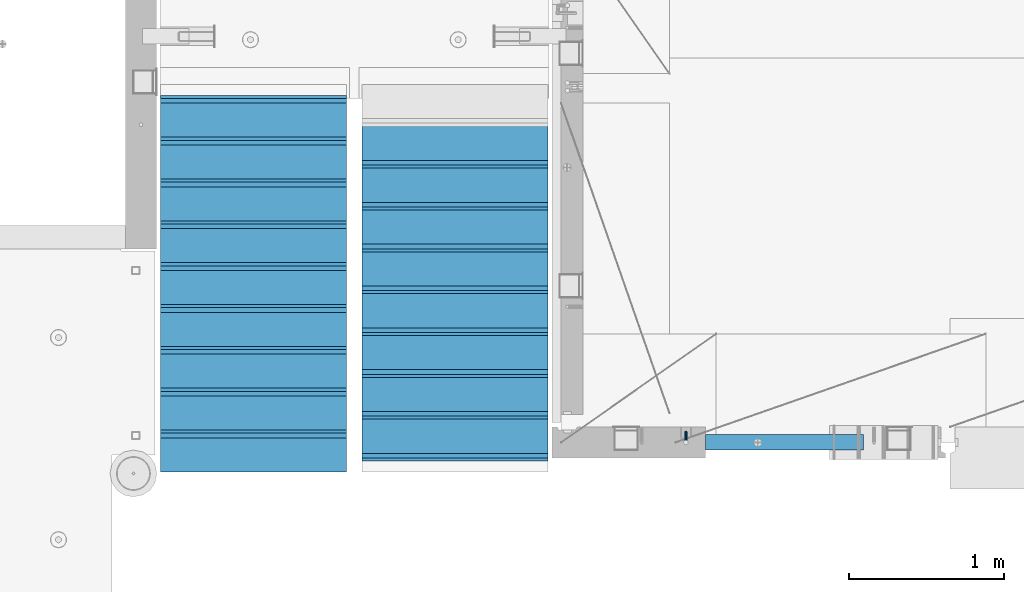
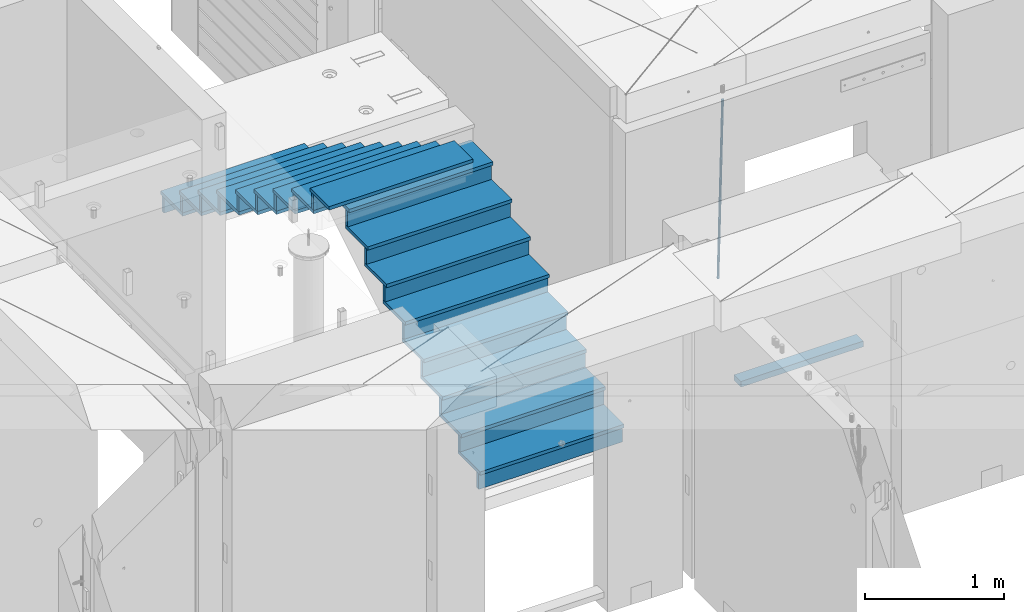
# One storey, part 113 of 334: 36 beams, 3 elements without a shape of their own.
"""IFC2X3 building model written with IfcOpenShell, lengths in millimetres."""

import ifcopenshell
import ifcopenshell.guid

model = None  # the IFC model being written
_history = None  # IfcOwnerHistory: only IFC2X3 demands one
_inside = {}  # id of a spatial element -> (the spatial element, [elements in it])
_under = {}  # id of a project, library or spatial element -> (it, [spatial elements below it])
_declared = {}  # id of a project -> (the project, [libraries it declares])
_typed = {}  # id of a type object -> (the type object, [elements of that type])
_made_of = {}  # id of a material, layer set ... -> (it, [elements and type objects made of it])


def new_model(schema):
    """Start an empty IFC model of exactly this schema.

    Asked for "IFC4X3", IfcOpenShell would pick the latest addendum, in which some entities
    have other attributes; the version numbers below select the first issue.
    IFC2X3 requires an IfcOwnerHistory on every rooted entity: one is made here for all.
    """
    global model, _history
    if schema == "IFC4X3":
        model = ifcopenshell.file(schema_version=(4, 3, 0, 0))
    else:
        model = ifcopenshell.file(schema=schema)
    _inside.clear()
    _under.clear()
    _declared.clear()
    _typed.clear()
    _made_of.clear()
    _history = None
    if model.schema == "IFC2X3":
        org = make("IfcOrganization", Name="unknown")
        user = make(
            "IfcPersonAndOrganization",
            ThePerson=make("IfcPerson", FamilyName="unknown"),
            TheOrganization=org,
        )
        app = make(
            "IfcApplication",
            ApplicationDeveloper=org,
            Version="unknown",
            ApplicationFullName="unknown",
            ApplicationIdentifier="unknown",
        )
        _history = make(
            "IfcOwnerHistory",
            OwningUser=user,
            OwningApplication=app,
            ChangeAction="ADDED",
            CreationDate=0,
        )
    return model


def make(cls, **values):
    """One entity of the class cls with the attributes given. An attribute that is None is left unset."""
    return model.create_entity(
        cls, **{name: value for name, value in values.items() if value is not None}
    )


def rooted(cls, **values):
    """An entity with a GlobalId (a new one), such as an element, a storey or a relation."""
    return make(cls, GlobalId=ifcopenshell.guid.new(), OwnerHistory=_history, **values)


def si_unit(unit_type, name, prefix=None):
    """IfcSIUnit, for example si_unit("LENGTHUNIT", "METRE", prefix="MILLI")."""
    return make("IfcSIUnit", UnitType=unit_type, Prefix=prefix, Name=name)


def assignment(units):
    """IfcUnitAssignment: the units of a project."""
    return None if units is None else make("IfcUnitAssignment", Units=units)


def point(xyz):
    """IfcCartesianPoint."""
    return None if xyz is None else make("IfcCartesianPoint", Coordinates=xyz)


def direction(xyz):
    """IfcDirection."""
    return None if xyz is None else make("IfcDirection", DirectionRatios=xyz)


def frame(location, z_axis=None, x_axis=None):
    """IfcAxis2Placement3D, a coordinate frame: its origin and axes. An axis left out is left unset."""
    return make(
        "IfcAxis2Placement3D",
        Location=point(location),
        Axis=direction(z_axis),
        RefDirection=direction(x_axis),
    )


def origin_with_axes():
    """The frame at (0, 0, 0) with the z axis (0, 0, 1) and the x axis (1, 0, 0) written out."""
    return frame((0.0, 0.0, 0.0), z_axis=(0.0, 0.0, 1.0), x_axis=(1.0, 0.0, 0.0))


def place(relative_to, where):
    """IfcLocalPlacement: puts the frame where relative to a parent placement (None: the world)."""
    return make(
        "IfcLocalPlacement", PlacementRelTo=relative_to, RelativePlacement=where
    )


def context(
    kind, dimensions, precision=None, world=None, true_north=None, identifier=None
):
    """IfcGeometricRepresentationContext, for example the 3D "Model" context."""
    return make(
        "IfcGeometricRepresentationContext",
        ContextIdentifier=identifier,
        ContextType=kind,
        CoordinateSpaceDimension=dimensions,
        Precision=precision,
        WorldCoordinateSystem=world,
        TrueNorth=true_north,
    )


def subcontext(parent, identifier, kind, view, scale=None):
    """IfcGeometricRepresentationSubContext, for example "Body" below "Model"."""
    return make(
        "IfcGeometricRepresentationSubContext",
        ContextIdentifier=identifier,
        ContextType=kind,
        ParentContext=parent,
        TargetScale=scale,
        TargetView=view,
    )


def project(units=None, contexts=None):
    """IfcProject with its units and contexts."""
    return rooted(
        "IfcProject",
        Name="project",
        RepresentationContexts=contexts,
        UnitsInContext=assignment(units),
    )


def spatial(cls, under=None, at=None, **own):
    """A site, building, storey or space (cls), placed at a placement, below another one or the project."""
    s = rooted(cls, ObjectPlacement=at, **own)
    if under is not None:
        _under.setdefault(under.id(), (under, []))[1].append(s)
    return s


def faces_of(points, faces, orient=None, outer=None):
    """IfcFace entities. A face is a list of loops; a loop is a list of indices into points, from 0.

    orient and outer hold one flag for each loop. By default every Orientation is true, the
    first loop of a face is its IfcFaceOuterBound and the others are IfcFaceBound.
    """
    made = []
    for i, loops in enumerate(faces):
        bounds = []
        for j, loop in enumerate(loops):
            is_outer = j == 0 if outer is None else outer[i][j]
            bounds.append(
                make(
                    "IfcFaceOuterBound" if is_outer else "IfcFaceBound",
                    Bound=make("IfcPolyLoop", Polygon=[points[k] for k in loop]),
                    Orientation=True if orient is None else orient[i][j],
                )
            )
        made.append(make("IfcFace", Bounds=bounds))
    return made


def faceted_brep(points, faces, orient=None, outer=None, voids=None):
    """IfcFacetedBrep: a solid bounded by flat faces; with voids (closed shells), ...WithVoids."""
    shared = [point(p) for p in points]
    hull = make("IfcClosedShell", CfsFaces=faces_of(shared, faces, orient, outer))
    if voids is None:
        return make("IfcFacetedBrep", Outer=hull)
    return make(
        "IfcFacetedBrepWithVoids",
        Outer=hull,
        Voids=[
            make(cls, CfsFaces=faces_of(shared, fs, o, b)) for cls, fs, o, b in voids
        ],
    )


def shape(context_of_items, identifier, shape_type, items):
    """IfcShapeRepresentation: the items that make up one representation, for example the "Body"."""
    return make(
        "IfcShapeRepresentation",
        ContextOfItems=context_of_items,
        RepresentationIdentifier=identifier,
        RepresentationType=shape_type,
        Items=items,
    )


def material(Name=None, Category=None):
    """IfcMaterial."""
    return make("IfcMaterial", Name=Name, Category=Category)


def made_of(thing, what):
    """Note that an element or type object is made of a material, layer set ...; save() writes the relation."""
    if what is not None:
        _made_of.setdefault(what.id(), (what, []))[1].append(thing)
    return thing


def type_object(cls, material=None, **own):
    """A type object (cls), such as IfcWallType, which elements share."""
    return made_of(rooted(cls, **own), material)


def element(
    cls,
    number,
    at=None,
    inside=None,
    cuts=None,
    type_object=None,
    material=None,
    context=None,
    identifier="Body",
    shape_type=None,
    held_by="IfcProductDefinitionShape",
    body=None,
    shapes=None,
    **own,
):
    """One element of the class cls, such as IfcWall. Its Tag is "e" and its number.

    at: its placement. inside: the storey or other place that contains it. cuts: it is an
    opening in that element (IfcRelVoidsElement). A single representation is given by context,
    identifier, shape_type and body (its items); several are given by shapes. held_by: the class
    of the entity that holds the representations. save() writes the other relations.
    """
    e = rooted(cls, Tag="e%d" % number, ObjectPlacement=at, **own)
    if body is not None:
        shapes = [shape(context, identifier, shape_type, body)]
    if shapes is not None:
        e.Representation = make(held_by, Representations=shapes)
    if inside is not None:
        _inside.setdefault(inside.id(), (inside, []))[1].append(e)
    if cuts is not None:
        rooted(
            "IfcRelVoidsElement", RelatingBuildingElement=cuts, RelatedOpeningElement=e
        )
    if type_object is not None:
        _typed.setdefault(type_object.id(), (type_object, []))[1].append(e)
    return made_of(e, material)


def aggregate(whole, parts):
    """IfcRelAggregates: a whole, such as a stair, and the parts it consists of."""
    return rooted("IfcRelAggregates", RelatingObject=whole, RelatedObjects=parts)


def save(model, path):
    """Write the relations noted so far, then the file.

    IfcRelAggregates (storeys below a building ...), IfcRelContainedInSpatialStructure (elements
    in a storey), IfcRelDefinesByType, IfcRelAssociatesMaterial and IfcRelDeclares: one each for
    every whole, place, type object, material and project.
    """
    for whole, parts in _under.values():
        aggregate(whole, parts)
    for where, things in _inside.values():
        rooted(
            "IfcRelContainedInSpatialStructure",
            RelatedElements=things,
            RelatingStructure=where,
        )
    for kind, things in _typed.values():
        rooted("IfcRelDefinesByType", RelatedObjects=things, RelatingType=kind)
    for what, things in _made_of.values():
        rooted("IfcRelAssociatesMaterial", RelatedObjects=things, RelatingMaterial=what)
    for by, libraries in _declared.values():
        rooted("IfcRelDeclares", RelatingContext=by, RelatedDefinitions=libraries)
    model.write(path)


model = new_model("IFC2X3")

# Units and contexts
model_context = context("Model", 3, precision=1e-05, world=origin_with_axes())
body_context = subcontext(model_context, "Body", "Model", "MODEL_VIEW")
ifc_project = project(units=[si_unit("LENGTHUNIT", "METRE", prefix="MILLI"), si_unit("AREAUNIT", "SQUARE_METRE"), si_unit("VOLUMEUNIT", "CUBIC_METRE"), si_unit("MASSUNIT", "GRAM", prefix="KILO"), si_unit("TIMEUNIT", "SECOND"), si_unit("PLANEANGLEUNIT", "RADIAN"), si_unit("SOLIDANGLEUNIT", "STERADIAN"), si_unit("THERMODYNAMICTEMPERATUREUNIT", "DEGREE_CELSIUS"), si_unit("LUMINOUSINTENSITYUNIT", "LUMEN")], contexts=[model_context])

# Site, building, storey
site_placement = place(None, origin_with_axes())
site = spatial("IfcSite", under=ifc_project, at=site_placement, CompositionType="ELEMENT")
building_placement = place(site_placement, origin_with_axes())
building = spatial("IfcBuilding", under=site, at=building_placement, CompositionType="ELEMENT")
storey_placement = place(building_placement, origin_with_axes())
storey = spatial("IfcBuildingStorey", under=building, at=storey_placement, Name="3", CompositionType="ELEMENT", Elevation=0.0)

# Assembly, beams
assembly_1_placement = place(storey_placement, origin_with_axes())
assembly_1 = element("IfcElementAssembly", 1, at=assembly_1_placement, inside=storey, AssemblyPlace="NOTDEFINED", PredefinedType="REINFORCEMENT_UNIT")
ifc_material_1 = material()
beam_type_1 = type_object("IfcBeamType", Name="D20", PredefinedType="NOTDEFINED")
beam_1_placement = place(assembly_1_placement, frame((23075.0006866416, 17045.0000022791, 88790.0), z_axis=(0.00020576299992186, -0.999642804629538, -0.0267249099901004), x_axis=(-4.30000201928125e-08, -0.0267249099948059, 0.999642825806181)))
beam_1 = element("IfcBeam", 2, at=beam_1_placement, type_object=beam_type_1, material=ifc_material_1, Name="JM20", ObjectType="D20", context=body_context, shape_type="Brep", body=[
    faceted_brep([(0.0, -10.0, 0.0), (-4.19531716033816e-08, -7.07106781186667, -7.07106781187031), (60.4266690400545, -7.0710677960451, -7.07106780570757), (60.4266690441291, -9.99999998418934, 6.15546014159918e-09), (0.0, 0.0, -10.0), (60.426669036824, 1.58106558956206e-08, -9.99999999384454), (4.196772351861e-08, 7.07106781186303, -7.07106781186667), (60.4266690363438, 7.07106782768096, -7.07106780570757), (0.0, 10.0, 0.0), (60.4266690388904, 10.0000000158179, 6.15182216279209e-09), (4.196772351861e-08, 7.07106781185939, 7.07106781185939), (60.4266690429649, 7.07106782768096, 7.07106781802577), (0.0, 0.0, 10.0), (60.4266690461809, 1.58179318532348e-08, 10.0000000061555), (-4.19531716033816e-08, -7.07106781187031, 7.07106781185939), (60.4266690466611, -7.07106779605238, 7.07106781802213), (61.0378400410118, -7.07106779588503, -7.07106780564936), (60.991799419251, -9.99999998403655, 6.21366780251265e-09), (61.0569027789461, 1.5985278878361e-08, -9.99999999378269), (61.0378209396877, 7.07106782784831, -7.07106780564936), (60.9917724058905, 10.0000000159635, 6.21366780251265e-09), (60.9457317841297, 7.07106782781193, 7.0710678180767), (60.9266690461809, 1.59488990902901e-08, 10.0000000062028), (60.9457508854539, -7.07106779591413, 7.0710678180767), (61.6489592143771, -7.07106614513759, -7.06310863441468), (61.5568818710308, -9.9999984576425, 0.00735959856683621), (61.6870830769039, 1.71821739058942e-06, -9.99179257185824), (61.6489210170112, 7.07106947854481, -7.06310888312146), (61.556827851804, 10.0000015422847, 0.00735924683976918), (61.4647505084577, 7.07106922979438, 7.07782747982128), (61.4266266459163, 1.36643211590126e-06, 10.0065114172685), (61.464788705809, -7.07106639389531, 7.07782772852806), (176.543135720174, -7.07075579406956, -5.56673531796696), (176.451058376813, -9.99968810657447, 1.50373291501455), (176.581259582701, 0.000312069292704109, -8.49541925541052), (176.543097522794, 7.07137982961285, -5.56673556667374), (176.451004357587, 10.00031189336, 1.50373256329476), (176.35892701424, 7.07137958085514, 8.57420079627263), (176.320803151699, 0.000311717507429421, 11.5028847337162), (176.358965211621, -7.07075604281999, 8.57420104497578), (177.098753836006, -7.07075429323595, -5.55949898843028), (176.98362511232, -9.99968666800123, 1.510669025065), (177.146421932586, 0.000313595905026887, -8.48805862247536), (177.098706077581, 7.07138133041735, -5.55949936166144), (176.983557571715, 10.0003133318824, 1.51066849724157), (176.868428848029, 7.07138095712435, 8.58083651073321), (176.820760751449, 0.000313067976094317, 11.5093961447819), (176.868476606425, -7.07075466652896, 8.58083688396073), (177.654312950661, -7.07075204110879, -5.54863964998367), (177.516135294456, -9.99968450931192, 1.52107783331303), (177.711524267797, 0.000315886711177882, -8.47701274570863), (177.654255632195, 7.07138358250813, -5.54864021007961), (177.516054233929, 10.0003154905207, 1.5210770412159), (177.377876577739, 7.0713830223176, 8.59079452451624), (177.320665260588, 0.000315094497636892, 11.5191676202448), (177.377933896176, -7.07075260129932, 8.59079508461218), (299.580241614967, -7.07025777803938, -3.16539205229128), (299.442063958748, -9.99919024624614, 3.90432543100542), (299.637452932104, 0.000810149780591019, -6.09376514801625), (299.58018429653, 7.07187784557391, -3.16539261238358), (299.441982898265, 10.0008097535901, 3.90432463891557), (299.303805242045, 7.07187728538338, 10.974042122205), (299.246593924894, 0.00080935756341205, 13.9024152179336), (299.303862560482, -7.07025833822991, 10.9740426822973), (300.088882651282, -7.07025571611666, -3.15544980669438), (299.971788958996, -9.99918809853989, 3.91467979818117), (300.137357441272, 0.000812176291219657, -6.0839936725497), (300.088834180511, 7.07187990754028, -3.15545019384081), (299.971753863239, 10.0008119014747, 3.91467990454839), (299.854660170953, 7.07187951844026, 10.9848095094276), (299.806185380992, 0.000811626032373169, 13.9133533752902), (299.854708641738, -7.07025610520941, 10.9848098965813), (300.597573977022, -7.07025429077839, -3.14854421417112), (300.501599787152, -9.99918661431002, 3.92187219230618), (300.637311376035, 0.00081357714952901, -6.07720669196715), (300.597534354776, 7.07188133290401, -3.14854448120241), (300.501543752835, 10.0008133856099, 3.92187181466215), (300.40556956298, 7.07188106207104, 10.9922882211395), (300.365832163967, 0.000813194146758178, 13.9209506989318), (300.405609185211, -7.07025456160045, 10.9922884881707), (1494.60304651056, -7.06690872122999, 13.060333041718), (1494.50707232069, -9.99584104476162, 20.1307494481916), (1494.64278390956, 0.00415914670156781, 10.1316705639183), (1494.6030068883, 7.07522690244878, 13.0603327746867), (1494.50701628637, 10.004158955162, 20.1307490705476), (1494.4110420965, 7.07522663162308, 27.2011654770249), (1494.3713046975, 0.00415876370243495, 30.1298279548209), (1494.41108171875, -7.06690899205205, 27.2011657440526), (1495.1211563645, -7.06690726950183, 13.067366492749), (1495.00702625545, -9.99583964390331, 20.1375364287742), (1495.20660775043, 0.00416072652296862, 10.1393245920117), (1495.21332415029, 7.07522861253892, 13.0686179608165), (1495.13737118813, 10.0041607213934, 20.1393062718889), (1495.02324107911, 7.07522834699193, 27.2094762079141), (1494.93778969315, 0.00416035097441636, 30.1375181086514), (1494.93107329329, -7.06690753504881, 27.2082247398503), (1495.63922435709, -7.07365070849846, 13.0742491942874), (1495.5069397148, -10.00235861486, 20.1441724282631), (1495.77038591086, -0.00317370150150964, 10.1468279224828), (1495.82359171678, 7.06728286786529, 13.0767522910828), (1495.76767453534, 9.99594143344802, 20.1477123416917), (1495.63538989302, 7.0672335270865, 27.2176355756565), (1495.50422833927, -0.00324347991045215, 30.1450568474684), (1495.45102253335, -7.07370004928453, 27.2151324788683), (1517.48046966468, -7.35846502584536, 13.3649345949125), (1517.34818502239, -10.2871729322142, 20.4348578288809), (1517.61163121845, -0.287988018848409, 10.4375133231042), (1517.66483702436, 6.78246855052203, 13.3674376917079), (1517.60891984291, 9.71112711610476, 20.4383977423167), (1517.47663520063, 6.78241920973232, 27.5083209762815), (1517.34547364687, -0.288057797257352, 30.4357422480862), (1517.29226784095, -7.35851436663143, 27.5058178794898), (1518.11590717161, -7.36675126123009, 13.3733916404526), (1518.00827439407, -10.295780632965, 20.4436429663911), (1518.18994308249, -0.295529324139352, 10.4452100827657), (1518.18701289421, 6.77565927010801, 13.3743873367348), (1518.10883307132, 9.70460814510079, 20.4450510935785), (1518.00120029377, 6.77557877335857, 27.515302419517), (1517.9271643829, -0.295643163732166, 30.4434839772002), (1517.93009457119, -7.36683175797953, 27.5143067232275), (1518.75139849893, -7.36487536471395, 13.3816537936873), (1518.66841952164, -10.2938120781764, 20.4522328350286), (1518.76830418318, -0.293831718903675, 10.452712053142), (1518.7092334538, 6.77719739167878, 13.3811419616068), (1518.60878914295, 9.7060990139762, 20.4515089951637), (1518.52581016565, 6.77716230052101, 27.522088036505), (1518.50890448141, -0.293881345296541, 30.4510297770539), (1518.56797521077, -7.36491045587172, 27.5225998685855), (1618.77218426704, -7.06661321754655, 14.6790318180938), (1618.68920528975, -9.99554993101265, 21.7496108594387), (1618.78908995127, 0.0044304282637313, 11.7500900775485), (1618.73001922191, 7.07545953884255, 14.6785199860096), (1618.62957491104, 10.0043611611436, 21.748887019563), (1618.54659593375, 7.07542444768478, 28.8194660609042), (1618.52969024952, 0.00438080187086598, 31.7484078014531), (1618.58876097888, -7.06664830870795, 28.819977892992)], [[[0, 1, 2, 3]], [[1, 4, 5, 2]], [[4, 6, 7, 5]], [[6, 8, 9, 7]], [[8, 10, 11, 9]], [[10, 12, 13, 11]], [[12, 14, 15, 13]], [[14, 0, 3, 15]], [[14, 12, 10, 8, 6, 4, 1, 0]], [[3, 2, 16, 17]], [[2, 5, 18, 16]], [[5, 7, 19, 18]], [[7, 9, 20, 19]], [[9, 11, 21, 20]], [[11, 13, 22, 21]], [[13, 15, 23, 22]], [[15, 3, 17, 23]], [[17, 16, 24, 25]], [[16, 18, 26, 24]], [[18, 19, 27, 26]], [[19, 20, 28, 27]], [[20, 21, 29, 28]], [[21, 22, 30, 29]], [[22, 23, 31, 30]], [[23, 17, 25, 31]], [[25, 24, 32, 33]], [[24, 26, 34, 32]], [[26, 27, 35, 34]], [[27, 28, 36, 35]], [[28, 29, 37, 36]], [[29, 30, 38, 37]], [[30, 31, 39, 38]], [[31, 25, 33, 39]], [[33, 32, 40, 41]], [[32, 34, 42, 40]], [[34, 35, 43, 42]], [[35, 36, 44, 43]], [[36, 37, 45, 44]], [[37, 38, 46, 45]], [[38, 39, 47, 46]], [[39, 33, 41, 47]], [[41, 40, 48, 49]], [[40, 42, 50, 48]], [[42, 43, 51, 50]], [[43, 44, 52, 51]], [[44, 45, 53, 52]], [[45, 46, 54, 53]], [[46, 47, 55, 54]], [[47, 41, 49, 55]], [[49, 48, 56, 57]], [[48, 50, 58, 56]], [[50, 51, 59, 58]], [[51, 52, 60, 59]], [[52, 53, 61, 60]], [[53, 54, 62, 61]], [[54, 55, 63, 62]], [[55, 49, 57, 63]], [[57, 56, 64, 65]], [[56, 58, 66, 64]], [[58, 59, 67, 66]], [[59, 60, 68, 67]], [[60, 61, 69, 68]], [[61, 62, 70, 69]], [[62, 63, 71, 70]], [[63, 57, 65, 71]], [[65, 64, 72, 73]], [[64, 66, 74, 72]], [[66, 67, 75, 74]], [[67, 68, 76, 75]], [[68, 69, 77, 76]], [[69, 70, 78, 77]], [[70, 71, 79, 78]], [[71, 65, 73, 79]], [[73, 72, 80, 81]], [[72, 74, 82, 80]], [[74, 75, 83, 82]], [[75, 76, 84, 83]], [[76, 77, 85, 84]], [[77, 78, 86, 85]], [[78, 79, 87, 86]], [[79, 73, 81, 87]], [[81, 80, 88, 89]], [[80, 82, 90, 88]], [[82, 83, 91, 90]], [[83, 84, 92, 91]], [[84, 85, 93, 92]], [[85, 86, 94, 93]], [[86, 87, 95, 94]], [[87, 81, 89, 95]], [[89, 88, 96, 97]], [[88, 90, 98, 96]], [[90, 91, 99, 98]], [[91, 92, 100, 99]], [[92, 93, 101, 100]], [[93, 94, 102, 101]], [[94, 95, 103, 102]], [[95, 89, 97, 103]], [[97, 96, 104, 105]], [[96, 98, 106, 104]], [[98, 99, 107, 106]], [[99, 100, 108, 107]], [[100, 101, 109, 108]], [[101, 102, 110, 109]], [[102, 103, 111, 110]], [[103, 97, 105, 111]], [[105, 104, 112, 113]], [[104, 106, 114, 112]], [[106, 107, 115, 114]], [[107, 108, 116, 115]], [[108, 109, 117, 116]], [[109, 110, 118, 117]], [[110, 111, 119, 118]], [[111, 105, 113, 119]], [[113, 112, 120, 121]], [[112, 114, 122, 120]], [[114, 115, 123, 122]], [[115, 116, 124, 123]], [[116, 117, 125, 124]], [[117, 118, 126, 125]], [[118, 119, 127, 126]], [[119, 113, 121, 127]], [[121, 120, 128, 129]], [[120, 122, 130, 128]], [[122, 123, 131, 130]], [[123, 124, 132, 131]], [[124, 125, 133, 132]], [[125, 126, 134, 133]], [[126, 127, 135, 134]], [[127, 121, 129, 135]], [[130, 131, 132, 133, 134, 135, 129, 128]]]),
])
ifc_material_2 = material(Name="TIMBER/T24")
beam_type_2 = type_object("IfcBeamType", PredefinedType="NOTDEFINED")
beam_2_placement = place(assembly_1_placement, frame((23200.0006866455, 16980.0, 87880.0), z_axis=(0.0, 0.0, 1.0), x_axis=(1.0, 0.0, 0.0)))
beam_2 = element("IfcBeam", 3, at=beam_2_placement, type_object=beam_type_2, material=ifc_material_2, context=body_context, shape_type="Brep", body=[
    faceted_brep([(0.0, 50.0, -25.0), (0.0, 50.0, 25.0), (1020.0, 50.0, 25.0), (1020.0, 50.0, -25.0), (0.0, -50.0, 25.0), (1020.0, -50.0, 25.0), (0.0, -50.0, -25.0), (1020.0, -50.0, -25.0)], [[[0, 1, 2, 3]], [[1, 4, 5, 2]], [[4, 6, 7, 5]], [[6, 0, 3, 7]], [[5, 7, 3, 2]], [[6, 4, 1, 0]]]),
])
aggregate(assembly_1, [beam_1, beam_2])

assembly_2_placement = place(storey_placement, origin_with_axes())
assembly_2 = element("IfcElementAssembly", 4, at=assembly_2_placement, inside=storey, Name="E9", AssemblyPlace="NOTDEFINED", PredefinedType="NOTDEFINED")
ifc_material_3 = material(Name="Undefined/C32/40")
beam_type_3 = type_object("IfcBeamType", PredefinedType="NOTDEFINED")
beam_3_placement = place(assembly_2_placement, frame((20885.0002457424, 17024.9998138874, 90662.1), z_axis=(0.0, 1.0, 0.0), x_axis=(-1.0, 3.00000001838171e-08, 0.0)))
beam_3 = element("IfcBeam", 5, at=beam_3_placement, type_object=beam_type_3, material=ifc_material_3, Name="E9", context=body_context, shape_type="Brep", body=[
    faceted_brep([(0.0, 68.5, -15.0), (0.0, 68.5, 15.0), (1200.0, 68.5, 15.0), (1200.0, 68.5, -15.0), (0.0, -68.5, 15.0), (1200.0, -68.5, 15.0), (0.0, -68.5, -15.0), (1200.0, -68.5, -15.0)], [[[0, 1, 2, 3]], [[1, 4, 5, 2]], [[4, 6, 7, 5]], [[6, 0, 3, 7]], [[5, 7, 3, 2]], [[6, 4, 1, 0]]]),
])
beam_4_placement = place(assembly_2_placement, frame((20885.0002457424, 17294.9998138874, 90495.4), z_axis=(0.0, 1.0, 0.0), x_axis=(-1.0, 3.00000001838171e-08, 0.0)))
beam_4 = element("IfcBeam", 6, at=beam_4_placement, type_object=beam_type_3, material=ifc_material_3, Name="E9", context=body_context, shape_type="Brep", body=[
    faceted_brep([(0.0, 68.5, -15.0), (0.0, 68.5, 15.0), (1200.0, 68.5, 15.0), (1200.0, 68.5, -15.0), (0.0, -68.5, 15.0), (1200.0, -68.5, 15.0), (0.0, -68.5, -15.0), (1200.0, -68.5, -15.0)], [[[0, 1, 2, 3]], [[1, 4, 5, 2]], [[4, 6, 7, 5]], [[6, 0, 3, 7]], [[5, 7, 3, 2]], [[6, 4, 1, 0]]]),
])
beam_5_placement = place(assembly_2_placement, frame((20885.0002457424, 17564.9998138874, 90328.7), z_axis=(0.0, 1.0, 0.0), x_axis=(-1.0, 3.00000001838171e-08, 0.0)))
beam_5 = element("IfcBeam", 7, at=beam_5_placement, type_object=beam_type_3, material=ifc_material_3, Name="E9", context=body_context, shape_type="Brep", body=[
    faceted_brep([(0.0, 68.5, -15.0), (0.0, 68.5, 15.0), (1200.0, 68.5, 15.0), (1200.0, 68.5, -15.0), (0.0, -68.5, 15.0), (1200.0, -68.5, 15.0), (0.0, -68.5, -15.0), (1200.0, -68.5, -15.0)], [[[0, 1, 2, 3]], [[1, 4, 5, 2]], [[4, 6, 7, 5]], [[6, 0, 3, 7]], [[5, 7, 3, 2]], [[6, 4, 1, 0]]]),
])
beam_6_placement = place(assembly_2_placement, frame((20885.0002457424, 17834.9998138874, 90162.0), z_axis=(0.0, 1.0, 0.0), x_axis=(-1.0, 3.00000001838171e-08, 0.0)))
beam_6 = element("IfcBeam", 8, at=beam_6_placement, type_object=beam_type_3, material=ifc_material_3, Name="E9", context=body_context, shape_type="Brep", body=[
    faceted_brep([(0.0, 68.5, -15.0), (0.0, 68.5, 15.0), (1200.0, 68.5, 15.0), (1200.0, 68.5, -15.0), (0.0, -68.5, 15.0), (1200.0, -68.5, 15.0), (0.0, -68.5, -15.0), (1200.0, -68.5, -15.0)], [[[0, 1, 2, 3]], [[1, 4, 5, 2]], [[4, 6, 7, 5]], [[6, 0, 3, 7]], [[5, 7, 3, 2]], [[6, 4, 1, 0]]]),
])
beam_7_placement = place(assembly_2_placement, frame((20885.0002457424, 18104.9998138874, 89995.3), z_axis=(0.0, 1.0, 0.0), x_axis=(-1.0, 3.00000001838171e-08, 0.0)))
beam_7 = element("IfcBeam", 9, at=beam_7_placement, type_object=beam_type_3, material=ifc_material_3, Name="E9", context=body_context, shape_type="Brep", body=[
    faceted_brep([(0.0, 68.5, -15.0), (0.0, 68.5, 15.0), (1200.0, 68.5, 15.0), (1200.0, 68.5, -15.0), (0.0, -68.5, 15.0), (1200.0, -68.5, 15.0), (0.0, -68.5, -15.0), (1200.0, -68.5, -15.0)], [[[0, 1, 2, 3]], [[1, 4, 5, 2]], [[4, 6, 7, 5]], [[6, 0, 3, 7]], [[5, 7, 3, 2]], [[6, 4, 1, 0]]]),
])
beam_8_placement = place(assembly_2_placement, frame((20885.0002457424, 18374.9998138874, 89828.6), z_axis=(0.0, 1.0, 0.0), x_axis=(-1.0, 3.00000001838171e-08, 0.0)))
beam_8 = element("IfcBeam", 10, at=beam_8_placement, type_object=beam_type_3, material=ifc_material_3, Name="E9", context=body_context, shape_type="Brep", body=[
    faceted_brep([(0.0, 68.5, -15.0), (0.0, 68.5, 15.0), (1200.0, 68.5, 15.0), (1200.0, 68.5, -15.0), (0.0, -68.5, 15.0), (1200.0, -68.5, 15.0), (0.0, -68.5, -15.0), (1200.0, -68.5, -15.0)], [[[0, 1, 2, 3]], [[1, 4, 5, 2]], [[4, 6, 7, 5]], [[6, 0, 3, 7]], [[5, 7, 3, 2]], [[6, 4, 1, 0]]]),
])
beam_9_placement = place(assembly_2_placement, frame((20885.0002457424, 18644.9998138874, 89661.9), z_axis=(0.0, 1.0, 0.0), x_axis=(-1.0, 3.00000001838171e-08, 0.0)))
beam_9 = element("IfcBeam", 11, at=beam_9_placement, type_object=beam_type_3, material=ifc_material_3, Name="E9", context=body_context, shape_type="Brep", body=[
    faceted_brep([(0.0, 68.5, -15.0), (0.0, 68.5, 15.0), (1200.0, 68.5, 15.0), (1200.0, 68.5, -15.0), (0.0, -68.5, 15.0), (1200.0, -68.5, 15.0), (0.0, -68.5, -15.0), (1200.0, -68.5, -15.0)], [[[0, 1, 2, 3]], [[1, 4, 5, 2]], [[4, 6, 7, 5]], [[6, 0, 3, 7]], [[5, 7, 3, 2]], [[6, 4, 1, 0]]]),
])
beam_10_placement = place(assembly_2_placement, frame((20885.0002457424, 18914.9998138874, 89495.2), z_axis=(0.0, 1.0, 0.0), x_axis=(-1.0, 3.00000001838171e-08, 0.0)))
beam_10 = element("IfcBeam", 12, at=beam_10_placement, type_object=beam_type_3, material=ifc_material_3, Name="E9", context=body_context, shape_type="Brep", body=[
    faceted_brep([(0.0, 68.5, -15.0), (0.0, 68.5, 15.0), (1200.0, 68.5, 15.0), (1200.0, 68.5, -15.0), (0.0, -68.5, 15.0), (1200.0, -68.5, 15.0), (0.0, -68.5, -15.0), (1200.0, -68.5, -15.0)], [[[0, 1, 2, 3]], [[1, 4, 5, 2]], [[4, 6, 7, 5]], [[6, 0, 3, 7]], [[5, 7, 3, 2]], [[6, 4, 1, 0]]]),
])
beam_11_placement = place(assembly_2_placement, frame((20885.0002457424, 19184.9998138874, 89328.5), z_axis=(0.0, 1.0, 0.0), x_axis=(-1.0, 3.00000001838171e-08, 0.0)))
beam_11 = element("IfcBeam", 13, at=beam_11_placement, type_object=beam_type_3, material=ifc_material_3, Name="E9", context=body_context, shape_type="Brep", body=[
    faceted_brep([(0.0, 68.5, -15.0), (0.0, 68.5, 15.0), (1200.0, 68.5, 15.0), (1200.0, 68.5, -15.0), (0.0, -68.5, 15.0), (1200.0, -68.5, 15.0), (0.0, -68.5, -15.0), (1200.0, -68.5, -15.0)], [[[0, 1, 2, 3]], [[1, 4, 5, 2]], [[4, 6, 7, 5]], [[6, 0, 3, 7]], [[5, 7, 3, 2]], [[6, 4, 1, 0]]]),
])

assembly_3_placement = place(storey_placement, origin_with_axes())
assembly_3 = element("IfcElementAssembly", 14, at=assembly_3_placement, inside=storey, Name="E9", AssemblyPlace="NOTDEFINED", PredefinedType="NOTDEFINED")
beam_12_placement = place(assembly_3_placement, frame((20985.002175553, 18785.001025346, 88995.1036072969), z_axis=(0.0, -1.0, 0.0), x_axis=(1.0, 0.0, 0.0)))
beam_12 = element("IfcBeam", 15, at=beam_12_placement, type_object=beam_type_3, material=ifc_material_3, Name="E9", context=body_context, shape_type="Brep", body=[
    faceted_brep([(0.0, 68.5, -15.0), (0.0, 68.5, 15.0), (1200.0, 68.5, 15.0), (1200.0, 68.5, -15.0), (0.0, -68.5, 15.0), (1200.0, -68.5, 15.0), (0.0, -68.5, -15.0), (1200.0, -68.5, -15.0)], [[[0, 1, 2, 3]], [[1, 4, 5, 2]], [[4, 6, 7, 5]], [[6, 0, 3, 7]], [[5, 7, 3, 2]], [[6, 4, 1, 0]]]),
])
beam_13_placement = place(assembly_3_placement, frame((20985.002175553, 18515.001025346, 88828.4036072969), z_axis=(0.0, -1.0, 0.0), x_axis=(1.0, 0.0, 0.0)))
beam_13 = element("IfcBeam", 16, at=beam_13_placement, type_object=beam_type_3, material=ifc_material_3, Name="E9", context=body_context, shape_type="Brep", body=[
    faceted_brep([(0.0, 68.5, -15.0), (0.0, 68.5, 15.0), (1200.0, 68.5, 15.0), (1200.0, 68.5, -15.0), (0.0, -68.5, 15.0), (1200.0, -68.5, 15.0), (0.0, -68.5, -15.0), (1200.0, -68.5, -15.0)], [[[0, 1, 2, 3]], [[1, 4, 5, 2]], [[4, 6, 7, 5]], [[6, 0, 3, 7]], [[5, 7, 3, 2]], [[6, 4, 1, 0]]]),
])
beam_14_placement = place(assembly_3_placement, frame((20985.002175553, 18245.001025346, 88661.7036072969), z_axis=(0.0, -1.0, 0.0), x_axis=(1.0, 0.0, 0.0)))
beam_14 = element("IfcBeam", 17, at=beam_14_placement, type_object=beam_type_3, material=ifc_material_3, Name="E9", context=body_context, shape_type="Brep", body=[
    faceted_brep([(0.0, 68.5, -15.0), (0.0, 68.5, 15.0), (1200.0, 68.5, 15.0), (1200.0, 68.5, -15.0), (0.0, -68.5, 15.0), (1200.0, -68.5, 15.0), (0.0, -68.5, -15.0), (1200.0, -68.5, -15.0)], [[[0, 1, 2, 3]], [[1, 4, 5, 2]], [[4, 6, 7, 5]], [[6, 0, 3, 7]], [[5, 7, 3, 2]], [[6, 4, 1, 0]]]),
])
beam_15_placement = place(assembly_3_placement, frame((20985.002175553, 17975.001025346, 88495.0036072969), z_axis=(0.0, -1.0, 0.0), x_axis=(1.0, 0.0, 0.0)))
beam_15 = element("IfcBeam", 18, at=beam_15_placement, type_object=beam_type_3, material=ifc_material_3, Name="E9", context=body_context, shape_type="Brep", body=[
    faceted_brep([(0.0, 68.5, -15.0), (0.0, 68.5, 15.0), (1200.0, 68.5, 15.0), (1200.0, 68.5, -15.0), (0.0, -68.5, 15.0), (1200.0, -68.5, 15.0), (0.0, -68.5, -15.0), (1200.0, -68.5, -15.0)], [[[0, 1, 2, 3]], [[1, 4, 5, 2]], [[4, 6, 7, 5]], [[6, 0, 3, 7]], [[5, 7, 3, 2]], [[6, 4, 1, 0]]]),
])
beam_16_placement = place(assembly_3_placement, frame((20985.002175553, 17705.001025346, 88328.3036072969), z_axis=(0.0, -1.0, 0.0), x_axis=(1.0, 0.0, 0.0)))
beam_16 = element("IfcBeam", 19, at=beam_16_placement, type_object=beam_type_3, material=ifc_material_3, Name="E9", context=body_context, shape_type="Brep", body=[
    faceted_brep([(0.0, 68.5, -15.0), (0.0, 68.5, 15.0), (1200.0, 68.5, 15.0), (1200.0, 68.5, -15.0), (0.0, -68.5, 15.0), (1200.0, -68.5, 15.0), (0.0, -68.5, -15.0), (1200.0, -68.5, -15.0)], [[[0, 1, 2, 3]], [[1, 4, 5, 2]], [[4, 6, 7, 5]], [[6, 0, 3, 7]], [[5, 7, 3, 2]], [[6, 4, 1, 0]]]),
])
beam_17_placement = place(assembly_3_placement, frame((20985.002175553, 17435.001025346, 88161.6036072969), z_axis=(0.0, -1.0, 0.0), x_axis=(1.0, 0.0, 0.0)))
beam_17 = element("IfcBeam", 20, at=beam_17_placement, type_object=beam_type_3, material=ifc_material_3, Name="E9", context=body_context, shape_type="Brep", body=[
    faceted_brep([(0.0, 68.5, -15.0), (0.0, 68.5, 15.0), (1200.0, 68.5, 15.0), (1200.0, 68.5, -15.0), (0.0, -68.5, 15.0), (1200.0, -68.5, 15.0), (0.0, -68.5, -15.0), (1200.0, -68.5, -15.0)], [[[0, 1, 2, 3]], [[1, 4, 5, 2]], [[4, 6, 7, 5]], [[6, 0, 3, 7]], [[5, 7, 3, 2]], [[6, 4, 1, 0]]]),
])
beam_18_placement = place(assembly_3_placement, frame((20985.002175553, 17165.001025346, 87994.9036072969), z_axis=(0.0, -1.0, 0.0), x_axis=(1.0, 0.0, 0.0)))
beam_18 = element("IfcBeam", 21, at=beam_18_placement, type_object=beam_type_3, material=ifc_material_3, Name="E9", context=body_context, shape_type="Brep", body=[
    faceted_brep([(0.0, 68.5, -15.0), (0.0, 68.5, 15.0), (1200.0, 68.5, 15.0), (1200.0, 68.5, -15.0), (0.0, -68.5, 15.0), (1200.0, -68.5, 15.0), (0.0, -68.5, -15.0), (1200.0, -68.5, -15.0)], [[[0, 1, 2, 3]], [[1, 4, 5, 2]], [[4, 6, 7, 5]], [[6, 0, 3, 7]], [[5, 7, 3, 2]], [[6, 4, 1, 0]]]),
])
beam_19_placement = place(assembly_3_placement, frame((20985.002175553, 16895.001025346, 87828.2036072969), z_axis=(0.0, -1.0, 0.0), x_axis=(1.0, 0.0, 0.0)))
beam_19 = element("IfcBeam", 22, at=beam_19_placement, type_object=beam_type_3, material=ifc_material_3, Name="E9", context=body_context, shape_type="Brep", body=[
    faceted_brep([(0.0, 68.5, -15.0), (0.0, 68.5, 15.0), (1200.0, 68.5, 15.0), (1200.0, 68.5, -15.0), (0.0, -68.5, 15.0), (1200.0, -68.5, 15.0), (0.0, -68.5, -15.0), (1200.0, -68.5, -15.0)], [[[0, 1, 2, 3]], [[1, 4, 5, 2]], [[4, 6, 7, 5]], [[6, 0, 3, 7]], [[5, 7, 3, 2]], [[6, 4, 1, 0]]]),
])

# Beam
beam_type_4 = type_object("IfcBeamType", PredefinedType="NOTDEFINED")
beam_20_placement = place(assembly_2_placement, frame((20885.0002457424, 17169.9998138874, 90578.6), z_axis=(0.0, 1.0, 0.0), x_axis=(-1.0, 3.00000001838171e-08, 0.0)))
beam_20 = element("IfcBeam", 23, at=beam_20_placement, type_object=beam_type_4, material=ifc_material_3, Name="E9", context=body_context, shape_type="Brep", body=[
    faceted_brep([(0.0, 15.0, -160.0), (0.0, 15.0, 160.0), (1200.0, 15.0, 160.0), (1200.0, 15.0, -160.0), (0.0, -15.0, 160.0), (1200.0, -15.0, 160.0), (0.0, -15.0, -160.0), (1200.0, -15.0, -160.0)], [[[0, 1, 2, 3]], [[1, 4, 5, 2]], [[4, 6, 7, 5]], [[6, 0, 3, 7]], [[5, 7, 3, 2]], [[6, 4, 1, 0]]]),
])

beam_21_placement = place(assembly_2_placement, frame((20885.0002457424, 17439.9998138874, 90411.9), z_axis=(0.0, 1.0, 0.0), x_axis=(-1.0, 3.00000001838171e-08, 0.0)))
beam_21 = element("IfcBeam", 24, at=beam_21_placement, type_object=beam_type_4, material=ifc_material_3, Name="E9", context=body_context, shape_type="Brep", body=[
    faceted_brep([(0.0, 15.0, -160.0), (0.0, 15.0, 160.0), (1200.0, 15.0, 160.0), (1200.0, 15.0, -160.0), (0.0, -15.0, 160.0), (1200.0, -15.0, 160.0), (0.0, -15.0, -160.0), (1200.0, -15.0, -160.0)], [[[0, 1, 2, 3]], [[1, 4, 5, 2]], [[4, 6, 7, 5]], [[6, 0, 3, 7]], [[5, 7, 3, 2]], [[6, 4, 1, 0]]]),
])

beam_22_placement = place(assembly_2_placement, frame((20885.0002457424, 17709.9998138874, 90245.2), z_axis=(0.0, 1.0, 0.0), x_axis=(-1.0, 3.00000001838171e-08, 0.0)))
beam_22 = element("IfcBeam", 25, at=beam_22_placement, type_object=beam_type_4, material=ifc_material_3, Name="E9", context=body_context, shape_type="Brep", body=[
    faceted_brep([(0.0, 15.0, -160.0), (0.0, 15.0, 160.0), (1200.0, 15.0, 160.0), (1200.0, 15.0, -160.0), (0.0, -15.0, 160.0), (1200.0, -15.0, 160.0), (0.0, -15.0, -160.0), (1200.0, -15.0, -160.0)], [[[0, 1, 2, 3]], [[1, 4, 5, 2]], [[4, 6, 7, 5]], [[6, 0, 3, 7]], [[5, 7, 3, 2]], [[6, 4, 1, 0]]]),
])

beam_23_placement = place(assembly_2_placement, frame((20885.0002457424, 17979.9998138874, 90078.5), z_axis=(0.0, 1.0, 0.0), x_axis=(-1.0, 3.00000001838171e-08, 0.0)))
beam_23 = element("IfcBeam", 26, at=beam_23_placement, type_object=beam_type_4, material=ifc_material_3, Name="E9", context=body_context, shape_type="Brep", body=[
    faceted_brep([(0.0, 15.0, -160.0), (0.0, 15.0, 160.0), (1200.0, 15.0, 160.0), (1200.0, 15.0, -160.0), (0.0, -15.0, 160.0), (1200.0, -15.0, 160.0), (0.0, -15.0, -160.0), (1200.0, -15.0, -160.0)], [[[0, 1, 2, 3]], [[1, 4, 5, 2]], [[4, 6, 7, 5]], [[6, 0, 3, 7]], [[5, 7, 3, 2]], [[6, 4, 1, 0]]]),
])

beam_24_placement = place(assembly_2_placement, frame((20885.0002457424, 18249.9998138874, 89911.8), z_axis=(0.0, 1.0, 0.0), x_axis=(-1.0, 3.00000001838171e-08, 0.0)))
beam_24 = element("IfcBeam", 27, at=beam_24_placement, type_object=beam_type_4, material=ifc_material_3, Name="E9", context=body_context, shape_type="Brep", body=[
    faceted_brep([(0.0, 15.0, -160.0), (0.0, 15.0, 160.0), (1200.0, 15.0, 160.0), (1200.0, 15.0, -160.0), (0.0, -15.0, 160.0), (1200.0, -15.0, 160.0), (0.0, -15.0, -160.0), (1200.0, -15.0, -160.0)], [[[0, 1, 2, 3]], [[1, 4, 5, 2]], [[4, 6, 7, 5]], [[6, 0, 3, 7]], [[5, 7, 3, 2]], [[6, 4, 1, 0]]]),
])

beam_25_placement = place(assembly_2_placement, frame((20885.0002457424, 18519.9998138874, 89745.1), z_axis=(0.0, 1.0, 0.0), x_axis=(-1.0, 3.00000001838171e-08, 0.0)))
beam_25 = element("IfcBeam", 28, at=beam_25_placement, type_object=beam_type_4, material=ifc_material_3, Name="E9", context=body_context, shape_type="Brep", body=[
    faceted_brep([(0.0, 15.0, -160.0), (0.0, 15.0, 160.0), (1200.0, 15.0, 160.0), (1200.0, 15.0, -160.0), (0.0, -15.0, 160.0), (1200.0, -15.0, 160.0), (0.0, -15.0, -160.0), (1200.0, -15.0, -160.0)], [[[0, 1, 2, 3]], [[1, 4, 5, 2]], [[4, 6, 7, 5]], [[6, 0, 3, 7]], [[5, 7, 3, 2]], [[6, 4, 1, 0]]]),
])

beam_26_placement = place(assembly_2_placement, frame((20885.0002457424, 18789.9998138874, 89578.4), z_axis=(0.0, 1.0, 0.0), x_axis=(-1.0, 3.00000001838171e-08, 0.0)))
beam_26 = element("IfcBeam", 29, at=beam_26_placement, type_object=beam_type_4, material=ifc_material_3, Name="E9", context=body_context, shape_type="Brep", body=[
    faceted_brep([(0.0, 15.0, -160.0), (0.0, 15.0, 160.0), (1200.0, 15.0, 160.0), (1200.0, 15.0, -160.0), (0.0, -15.0, 160.0), (1200.0, -15.0, 160.0), (0.0, -15.0, -160.0), (1200.0, -15.0, -160.0)], [[[0, 1, 2, 3]], [[1, 4, 5, 2]], [[4, 6, 7, 5]], [[6, 0, 3, 7]], [[5, 7, 3, 2]], [[6, 4, 1, 0]]]),
])

beam_27_placement = place(assembly_2_placement, frame((20885.0002457424, 19059.9998138874, 89411.7), z_axis=(0.0, 1.0, 0.0), x_axis=(-1.0, 3.00000001838171e-08, 0.0)))
beam_27 = element("IfcBeam", 30, at=beam_27_placement, type_object=beam_type_4, material=ifc_material_3, Name="E9", context=body_context, shape_type="Brep", body=[
    faceted_brep([(0.0, 15.0, -160.0), (0.0, 15.0, 160.0), (1200.0, 15.0, 160.0), (1200.0, 15.0, -160.0), (0.0, -15.0, 160.0), (1200.0, -15.0, 160.0), (0.0, -15.0, -160.0), (1200.0, -15.0, -160.0)], [[[0, 1, 2, 3]], [[1, 4, 5, 2]], [[4, 6, 7, 5]], [[6, 0, 3, 7]], [[5, 7, 3, 2]], [[6, 4, 1, 0]]]),
])

beam_28_placement = place(assembly_3_placement, frame((20985.002175553, 18910.001025346, 89078.303607297), z_axis=(0.0, -1.0, 0.0), x_axis=(1.0, 0.0, 0.0)))
beam_28 = element("IfcBeam", 31, at=beam_28_placement, type_object=beam_type_4, material=ifc_material_3, Name="E9", context=body_context, shape_type="Brep", body=[
    faceted_brep([(0.0, 15.0, -160.0), (0.0, 15.0, 160.0), (1200.0, 15.0, 160.0), (1200.0, 15.0, -160.0), (0.0, -15.0, 160.0), (1200.0, -15.0, 160.0), (0.0, -15.0, -160.0), (1200.0, -15.0, -160.0)], [[[0, 1, 2, 3]], [[1, 4, 5, 2]], [[4, 6, 7, 5]], [[6, 0, 3, 7]], [[5, 7, 3, 2]], [[6, 4, 1, 0]]]),
])

beam_29_placement = place(assembly_3_placement, frame((20985.002175553, 18640.001025346, 88911.6036072969), z_axis=(0.0, -1.0, 0.0), x_axis=(1.0, 0.0, 0.0)))
beam_29 = element("IfcBeam", 32, at=beam_29_placement, type_object=beam_type_4, material=ifc_material_3, Name="E9", context=body_context, shape_type="Brep", body=[
    faceted_brep([(0.0, 15.0, -160.0), (0.0, 15.0, 160.0), (1200.0, 15.0, 160.0), (1200.0, 15.0, -160.0), (0.0, -15.0, 160.0), (1200.0, -15.0, 160.0), (0.0, -15.0, -160.0), (1200.0, -15.0, -160.0)], [[[0, 1, 2, 3]], [[1, 4, 5, 2]], [[4, 6, 7, 5]], [[6, 0, 3, 7]], [[5, 7, 3, 2]], [[6, 4, 1, 0]]]),
])

beam_30_placement = place(assembly_3_placement, frame((20985.002175553, 18370.001025346, 88744.9036072969), z_axis=(0.0, -1.0, 0.0), x_axis=(1.0, 0.0, 0.0)))
beam_30 = element("IfcBeam", 33, at=beam_30_placement, type_object=beam_type_4, material=ifc_material_3, Name="E9", context=body_context, shape_type="Brep", body=[
    faceted_brep([(0.0, 15.0, -160.0), (0.0, 15.0, 160.0), (1200.0, 15.0, 160.0), (1200.0, 15.0, -160.0), (0.0, -15.0, 160.0), (1200.0, -15.0, 160.0), (0.0, -15.0, -160.0), (1200.0, -15.0, -160.0)], [[[0, 1, 2, 3]], [[1, 4, 5, 2]], [[4, 6, 7, 5]], [[6, 0, 3, 7]], [[5, 7, 3, 2]], [[6, 4, 1, 0]]]),
])

beam_31_placement = place(assembly_3_placement, frame((20985.002175553, 18100.001025346, 88578.2036072969), z_axis=(0.0, -1.0, 0.0), x_axis=(1.0, 0.0, 0.0)))
beam_31 = element("IfcBeam", 34, at=beam_31_placement, type_object=beam_type_4, material=ifc_material_3, Name="E9", context=body_context, shape_type="Brep", body=[
    faceted_brep([(0.0, 15.0, -160.0), (0.0, 15.0, 160.0), (1200.0, 15.0, 160.0), (1200.0, 15.0, -160.0), (0.0, -15.0, 160.0), (1200.0, -15.0, 160.0), (0.0, -15.0, -160.0), (1200.0, -15.0, -160.0)], [[[0, 1, 2, 3]], [[1, 4, 5, 2]], [[4, 6, 7, 5]], [[6, 0, 3, 7]], [[5, 7, 3, 2]], [[6, 4, 1, 0]]]),
])

beam_32_placement = place(assembly_3_placement, frame((20985.002175553, 17830.001025346, 88411.5036072969), z_axis=(0.0, -1.0, 0.0), x_axis=(1.0, 0.0, 0.0)))
beam_32 = element("IfcBeam", 35, at=beam_32_placement, type_object=beam_type_4, material=ifc_material_3, Name="E9", context=body_context, shape_type="Brep", body=[
    faceted_brep([(0.0, 15.0, -160.0), (0.0, 15.0, 160.0), (1200.0, 15.0, 160.0), (1200.0, 15.0, -160.0), (0.0, -15.0, 160.0), (1200.0, -15.0, 160.0), (0.0, -15.0, -160.0), (1200.0, -15.0, -160.0)], [[[0, 1, 2, 3]], [[1, 4, 5, 2]], [[4, 6, 7, 5]], [[6, 0, 3, 7]], [[5, 7, 3, 2]], [[6, 4, 1, 0]]]),
])

beam_33_placement = place(assembly_3_placement, frame((20985.002175553, 17560.001025346, 88244.8036072969), z_axis=(0.0, -1.0, 0.0), x_axis=(1.0, 0.0, 0.0)))
beam_33 = element("IfcBeam", 36, at=beam_33_placement, type_object=beam_type_4, material=ifc_material_3, Name="E9", context=body_context, shape_type="Brep", body=[
    faceted_brep([(0.0, 15.0, -160.0), (0.0, 15.0, 160.0), (1200.0, 15.0, 160.0), (1200.0, 15.0, -160.0), (0.0, -15.0, 160.0), (1200.0, -15.0, 160.0), (0.0, -15.0, -160.0), (1200.0, -15.0, -160.0)], [[[0, 1, 2, 3]], [[1, 4, 5, 2]], [[4, 6, 7, 5]], [[6, 0, 3, 7]], [[5, 7, 3, 2]], [[6, 4, 1, 0]]]),
])

beam_34_placement = place(assembly_3_placement, frame((20985.002175553, 17290.001025346, 88078.1036072969), z_axis=(0.0, -1.0, 0.0), x_axis=(1.0, 0.0, 0.0)))
beam_34 = element("IfcBeam", 37, at=beam_34_placement, type_object=beam_type_4, material=ifc_material_3, Name="E9", context=body_context, shape_type="Brep", body=[
    faceted_brep([(0.0, 15.0, -160.0), (0.0, 15.0, 160.0), (1200.0, 15.0, 160.0), (1200.0, 15.0, -160.0), (0.0, -15.0, 160.0), (1200.0, -15.0, 160.0), (0.0, -15.0, -160.0), (1200.0, -15.0, -160.0)], [[[0, 1, 2, 3]], [[1, 4, 5, 2]], [[4, 6, 7, 5]], [[6, 0, 3, 7]], [[5, 7, 3, 2]], [[6, 4, 1, 0]]]),
])

beam_35_placement = place(assembly_3_placement, frame((20985.002175553, 17020.001025346, 87911.4036072969), z_axis=(0.0, -1.0, 0.0), x_axis=(1.0, 0.0, 0.0)))
beam_35 = element("IfcBeam", 38, at=beam_35_placement, type_object=beam_type_4, material=ifc_material_3, Name="E9", context=body_context, shape_type="Brep", body=[
    faceted_brep([(0.0, 15.0, -160.0), (0.0, 15.0, 160.0), (1200.0, 15.0, 160.0), (1200.0, 15.0, -160.0), (0.0, -15.0, 160.0), (1200.0, -15.0, 160.0), (0.0, -15.0, -160.0), (1200.0, -15.0, -160.0)], [[[0, 1, 2, 3]], [[1, 4, 5, 2]], [[4, 6, 7, 5]], [[6, 0, 3, 7]], [[5, 7, 3, 2]], [[6, 4, 1, 0]]]),
])

aggregate(assembly_3, [beam_28, beam_12, beam_29, beam_13, beam_30, beam_14, beam_31, beam_15, beam_32, beam_16, beam_33, beam_17, beam_34, beam_18, beam_35, beam_19])

beam_type_5 = type_object("IfcBeamType", PredefinedType="NOTDEFINED")
beam_36_placement = place(assembly_2_placement, frame((20885.0002457424, 16924.9998138874, 90745.3), z_axis=(0.0, 1.0, 0.0), x_axis=(-1.0, 3.00000001838171e-08, 0.0)))
beam_36 = element("IfcBeam", 39, at=beam_36_placement, type_object=beam_type_5, material=ifc_material_3, Name="E9", context=body_context, shape_type="Brep", body=[
    faceted_brep([(0.0, 15.0, -135.0), (0.0, 15.0, 135.0), (1200.0, 15.0, 135.0), (1200.0, 15.0, -135.0), (0.0, -15.0, 135.0), (1200.0, -15.0, 135.0), (0.0, -15.0, -135.0), (1200.0, -15.0, -135.0)], [[[0, 1, 2, 3]], [[1, 4, 5, 2]], [[4, 6, 7, 5]], [[6, 0, 3, 7]], [[5, 7, 3, 2]], [[6, 4, 1, 0]]]),
])

aggregate(assembly_2, [beam_3, beam_20, beam_4, beam_21, beam_5, beam_22, beam_6, beam_23, beam_7, beam_24, beam_8, beam_25, beam_9, beam_26, beam_10, beam_27, beam_36, beam_11])

save(model, "model.ifc")
